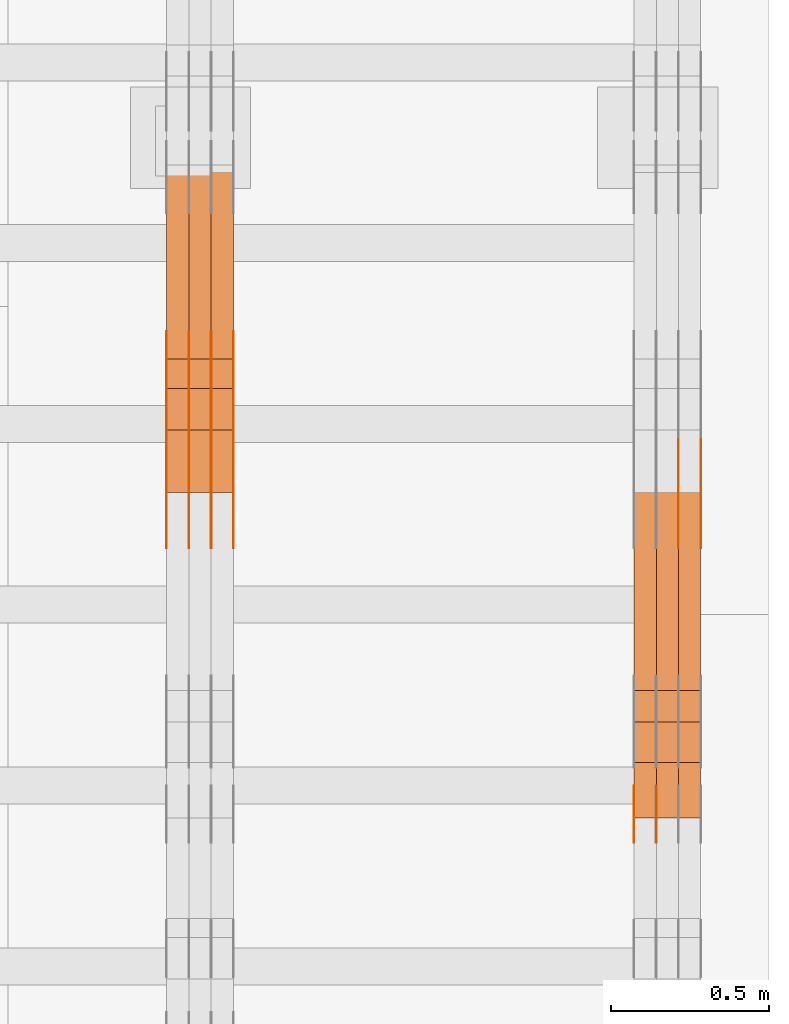
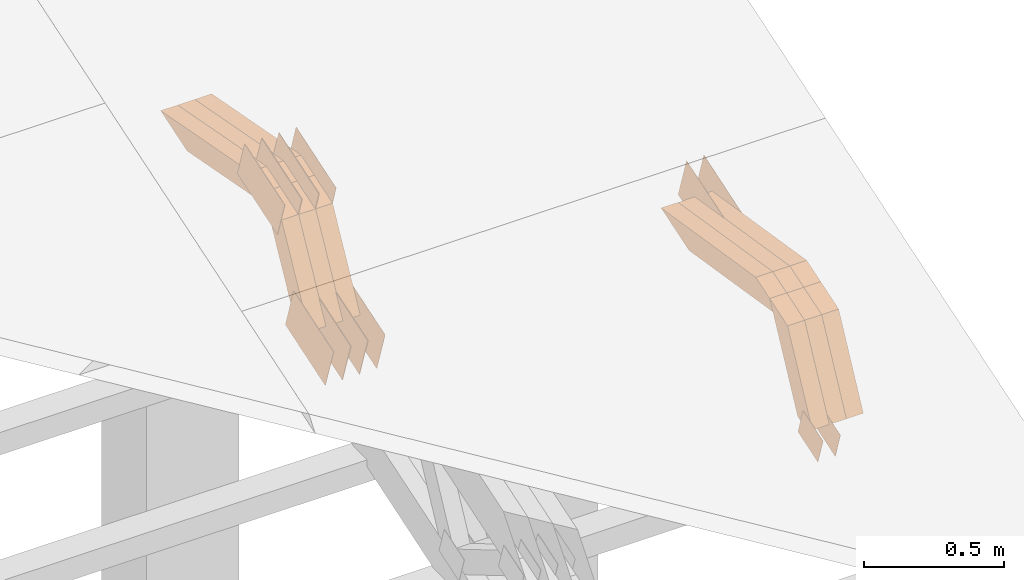
# One storey, part 319 of 385: 28 proxies.
"""IFC2X3 building model written with IfcOpenShell, lengths in millimetres."""

from ifc_helpers import new_model, entity, si_unit, converted_unit, derived_unit, direction, frame, origin, place, context, subcontext, project, spatial, polyline, outline, extrude, source, transform, mapped, material, type_object, type_shapes, element, save


model = new_model("IFC2X3")

# Units and contexts
model_context = context("Model", 3, precision=0.01, world=origin(), true_north=direction((6.12303176911189e-17, 1.0)))
body_context = subcontext(model_context, "Body", "Model", "MODEL_VIEW")
ifc_project = project(units=[si_unit("LENGTHUNIT", "METRE", prefix="MILLI"), si_unit("AREAUNIT", "SQUARE_METRE"), si_unit("VOLUMEUNIT", "CUBIC_METRE"), converted_unit("PLANEANGLEUNIT", "DEGREE", entity("IfcRatioMeasure", 0.0174532925199433), si_unit("PLANEANGLEUNIT", "RADIAN"), dimensions=[0, 0, 0, 0, 0, 0, 0]), si_unit("MASSUNIT", "GRAM", prefix="KILO"), derived_unit("MASSDENSITYUNIT", [(si_unit("MASSUNIT", "GRAM", prefix="KILO"), 1), (si_unit("LENGTHUNIT", "METRE"), -3)]), si_unit("TIMEUNIT", "SECOND"), si_unit("FREQUENCYUNIT", "HERTZ"), si_unit("THERMODYNAMICTEMPERATUREUNIT", "DEGREE_CELSIUS"), derived_unit("THERMALTRANSMITTANCEUNIT", [(si_unit("MASSUNIT", "GRAM", prefix="KILO"), 1), (si_unit("THERMODYNAMICTEMPERATUREUNIT", "KELVIN"), -1), (si_unit("TIMEUNIT", "SECOND"), -3)]), derived_unit("VOLUMETRICFLOWRATEUNIT", [(si_unit("LENGTHUNIT", "METRE"), 3), (si_unit("TIMEUNIT", "SECOND"), -1)]), si_unit("ELECTRICCURRENTUNIT", "AMPERE"), si_unit("ELECTRICVOLTAGEUNIT", "VOLT"), si_unit("POWERUNIT", "WATT"), si_unit("FORCEUNIT", "NEWTON", prefix="KILO"), si_unit("ILLUMINANCEUNIT", "LUX"), si_unit("LUMINOUSFLUXUNIT", "LUMEN"), si_unit("LUMINOUSINTENSITYUNIT", "CANDELA"), derived_unit("USERDEFINED", [(si_unit("MASSUNIT", "GRAM", prefix="KILO"), -1), (si_unit("LENGTHUNIT", "METRE"), -2), (si_unit("TIMEUNIT", "SECOND"), 3), (si_unit("LUMINOUSFLUXUNIT", "LUMEN"), 1)]), derived_unit("LINEARVELOCITYUNIT", [(si_unit("LENGTHUNIT", "METRE"), 1), (si_unit("TIMEUNIT", "SECOND"), -1)]), si_unit("PRESSUREUNIT", "PASCAL"), derived_unit("USERDEFINED", [(si_unit("LENGTHUNIT", "METRE"), -2), (si_unit("MASSUNIT", "GRAM", prefix="KILO"), 1), (si_unit("TIMEUNIT", "SECOND"), -2)])], contexts=[model_context])

# Site, building, storey
site_placement = place(None, origin())
site = spatial("IfcSite", under=ifc_project, at=site_placement, CompositionType="ELEMENT")
building_placement = place(site_placement, origin())
building = spatial("IfcBuilding", under=site, at=building_placement, CompositionType="ELEMENT")
storey_placement = place(building_placement, origin())
storey = spatial("IfcBuildingStorey", under=building, at=storey_placement, Name="Default", CompositionType="ELEMENT", Elevation=0.0)

# Proxies
ifc_material_1 = material(Name="IfcSurfaceStyle #621640")
building_element_proxy_type_1 = type_object("IfcBuildingElementProxyType", PredefinedType="NOTDEFINED", material=ifc_material_1)
shared_shape_1 = source(origin(), body_context, "Body", "SweptSolid", [
    extrude(outline(polyline([(-149.99966632326, -95.9999759039407), (149.999881095801, -95.9999759039407), (150.000557367591, 95.9999759039407), (-150.000772140132, 95.9999759039406), (-149.99966632326, -95.9999759039407)])), frame((150.000557367591, 96.0004291135906, 0.0), z_axis=(0.0, 0.0, 1.0), x_axis=(-1.0, 0.0, 0.0)), (0.0, 0.0, 1.0), 1.29999999999999),
])
type_shapes(building_element_proxy_type_1, [shared_shape_1])
proxy_1_placement = place(building_placement, frame((49861.3, 10934.7734375, 2766.8759765625), z_axis=(-1.0, 0.0, 0.0), x_axis=(0.0, 0.951056516295124, 0.309016994375039)))
element("IfcBuildingElementProxy", 1, at=proxy_1_placement, inside=storey, type_object=building_element_proxy_type_1, material=ifc_material_1, context=body_context, shape_type="MappedRepresentation", body=[
    mapped(shared_shape_1, transform((0.0, 0.0, 0.0), scale=1.0)),
])
ifc_material_2 = material(Name="IfcSurfaceStyle #621583")
building_element_proxy_type_2 = type_object("IfcBuildingElementProxyType", PredefinedType="NOTDEFINED", material=ifc_material_2)
shared_shape_2 = source(origin(), body_context, "Body", "SweptSolid", [
    extrude(outline(polyline([(-149.99966632326, -95.9999759039407), (149.999881095801, -95.9999759039407), (150.000557367591, 95.9999759039407), (-150.000772140132, 95.9999759039406), (-149.99966632326, -95.9999759039407)])), frame((150.000557367591, 96.0004291135906, 0.0), z_axis=(0.0, 0.0, 1.0), x_axis=(-1.0, 0.0, 0.0)), (0.0, 0.0, 1.0), 1.29999999999999),
])
type_shapes(building_element_proxy_type_2, [shared_shape_2])
proxy_2_placement = place(building_placement, frame((49790.0, 10934.7734375, 2766.8759765625), z_axis=(-1.0, 0.0, 0.0), x_axis=(0.0, 0.951056516295124, 0.309016994375039)))
element("IfcBuildingElementProxy", 2, at=proxy_2_placement, inside=storey, type_object=building_element_proxy_type_2, material=ifc_material_2, context=body_context, shape_type="MappedRepresentation", body=[
    mapped(shared_shape_2, transform((0.0, 0.0, 0.0), scale=1.0)),
])
ifc_material_3 = material(Name="IfcSurfaceStyle #621070")
building_element_proxy_type_3 = type_object("IfcBuildingElementProxyType", PredefinedType="NOTDEFINED", material=ifc_material_3)
shared_shape_3 = source(origin(), body_context, "Body", "SweptSolid", [
    extrude(outline(polyline([(-74.9998754286189, -60.0000016373433), (74.9998605591118, -60.0000016373433), (74.9998754286189, 60.0000016373433), (-74.9998605591118, 60.0000016373433), (-74.9998754286189, -60.0000016373433)])), frame((74.9999131819004, 60.0000016373433, 0.0), z_axis=(0.0, 0.0, 1.0), x_axis=(-1.0, 0.0, 0.0)), (0.0, 0.0, 1.0), 1.29999999999999),
])
type_shapes(building_element_proxy_type_3, [shared_shape_3])
proxy_3_placement = place(building_placement, frame((49721.3, 10004.8612689908, 2426.87628052724), z_axis=(-1.0, 0.0, 0.0), x_axis=(0.0, 0.951056516295124, 0.309016994375039)))
element("IfcBuildingElementProxy", 3, at=proxy_3_placement, inside=storey, type_object=building_element_proxy_type_3, material=ifc_material_3, context=body_context, shape_type="MappedRepresentation", body=[
    mapped(shared_shape_3, transform((0.0, 0.0, 0.0), scale=1.0)),
])
ifc_material_4 = material(Name="IfcSurfaceStyle #621013")
building_element_proxy_type_4 = type_object("IfcBuildingElementProxyType", PredefinedType="NOTDEFINED", material=ifc_material_4)
shared_shape_4 = source(origin(), body_context, "Body", "SweptSolid", [
    extrude(outline(polyline([(-74.9998754286189, -60.0000016373433), (74.9998605591118, -60.0000016373433), (74.9998754286189, 60.0000016373433), (-74.9998605591118, 60.0000016373433), (-74.9998754286189, -60.0000016373433)])), frame((74.9999131819004, 60.0000016373433, 0.0), z_axis=(0.0, 0.0, 1.0), x_axis=(-1.0, 0.0, 0.0)), (0.0, 0.0, 1.0), 1.29999999999999),
])
type_shapes(building_element_proxy_type_4, [shared_shape_4])
proxy_4_placement = place(building_placement, frame((49650.0, 10004.8612689908, 2426.87628052724), z_axis=(-1.0, 0.0, 0.0), x_axis=(0.0, 0.951056516295124, 0.309016994375039)))
element("IfcBuildingElementProxy", 4, at=proxy_4_placement, inside=storey, type_object=building_element_proxy_type_4, material=ifc_material_4, context=body_context, shape_type="MappedRepresentation", body=[
    mapped(shared_shape_4, transform((0.0, 0.0, 0.0), scale=1.0)),
])
ifc_material_5 = material(Name="IfcSurfaceStyle #600976")
building_element_proxy_type_5 = type_object("IfcBuildingElementProxyType", Name="T2-W5 600974", PredefinedType="NOTDEFINED", material=ifc_material_5)
shared_shape_5 = source(origin(), body_context, "Body", "SweptSolid", [
    extrude(outline(polyline([(-301.214270081322, -47.5000783565111), (303.980395954293, -47.5000783565111), (288.664123931657, 0.000197935560590153), (195.704076557203, 47.4999793887309), (-487.134326361831, 47.4999793887309), (-301.214270081322, -47.5000783565111)])), frame((303.980395954293, 47.5001815410909, 0.0), z_axis=(0.0, 0.0, 1.0), x_axis=(-1.0, 0.0, 0.0)), (0.0, 0.0, 1.0), 70.0),
])
type_shapes(building_element_proxy_type_5, [shared_shape_5])
proxy_5_placement = place(building_placement, frame((49860.0, 10379.2051671398, 2863.91176079486), z_axis=(-1.0, 0.0, 0.0), x_axis=(0.0, 0.987508363398486, -0.1575665961365)))
element("IfcBuildingElementProxy", 5, at=proxy_5_placement, inside=storey, type_object=building_element_proxy_type_5, material=ifc_material_5, Name="T2-W5", context=body_context, shape_type="MappedRepresentation", body=[
    mapped(shared_shape_5, transform((0.0, 0.0, 0.0), scale=1.0)),
])
ifc_material_6 = material(Name="IfcSurfaceStyle #600910")
building_element_proxy_type_6 = type_object("IfcBuildingElementProxyType", Name="T2-W5 600908", PredefinedType="NOTDEFINED", material=ifc_material_6)
shared_shape_6 = source(origin(), body_context, "Body", "SweptSolid", [
    extrude(outline(polyline([(-301.214270081322, -47.5000783565111), (303.980395954293, -47.5000783565111), (288.664123931657, 0.000197935560590153), (195.704076557203, 47.4999793887309), (-487.134326361831, 47.4999793887309), (-301.214270081322, -47.5000783565111)])), frame((303.980395954293, 47.5001815410909, 0.0), z_axis=(0.0, 0.0, 1.0), x_axis=(-1.0, 0.0, 0.0)), (0.0, 0.0, 1.0), 70.0),
])
type_shapes(building_element_proxy_type_6, [shared_shape_6])
proxy_6_placement = place(building_placement, frame((49790.0, 10379.2051671398, 2863.91176079486), z_axis=(-1.0, 0.0, 0.0), x_axis=(0.0, 0.987508363398486, -0.1575665961365)))
element("IfcBuildingElementProxy", 6, at=proxy_6_placement, inside=storey, type_object=building_element_proxy_type_6, material=ifc_material_6, Name="T2-W5", context=body_context, shape_type="MappedRepresentation", body=[
    mapped(shared_shape_6, transform((0.0, 0.0, 0.0), scale=1.0)),
])
ifc_material_7 = material(Name="IfcSurfaceStyle #600844")
building_element_proxy_type_7 = type_object("IfcBuildingElementProxyType", Name="T2-W5 600842", PredefinedType="NOTDEFINED", material=ifc_material_7)
shared_shape_7 = source(origin(), body_context, "Body", "SweptSolid", [
    extrude(outline(polyline([(-301.214270081322, -47.5000783565111), (303.980395954293, -47.5000783565111), (288.664123931657, 0.000197935560590153), (195.704076557203, 47.4999793887309), (-487.134326361831, 47.4999793887309), (-301.214270081322, -47.5000783565111)])), frame((303.980395954293, 47.5001815410909, 0.0), z_axis=(0.0, 0.0, 1.0), x_axis=(-1.0, 0.0, 0.0)), (0.0, 0.0, 1.0), 70.0),
])
type_shapes(building_element_proxy_type_7, [shared_shape_7])
proxy_7_placement = place(building_placement, frame((49720.0, 10379.2051671398, 2863.91176079486), z_axis=(-1.0, 0.0, 0.0), x_axis=(0.0, 0.987508363398486, -0.1575665961365)))
element("IfcBuildingElementProxy", 7, at=proxy_7_placement, inside=storey, type_object=building_element_proxy_type_7, material=ifc_material_7, Name="T2-W5", context=body_context, shape_type="MappedRepresentation", body=[
    mapped(shared_shape_7, transform((0.0, 0.0, 0.0), scale=1.0)),
])
ifc_material_8 = material(Name="IfcSurfaceStyle #600580")
building_element_proxy_type_8 = type_object("IfcBuildingElementProxyType", Name="T2-W37 600578", PredefinedType="NOTDEFINED", material=ifc_material_8)
shared_shape_8 = source(origin(), body_context, "Body", "SweptSolid", [
    extrude(outline(polyline([(111.787482004227, -179.289397746839), (245.990585035629, -179.289397746839), (-64.0177573255029, 131.410401861866), (-131.116409377007, 131.410958895698), (-162.643900337347, 95.757434736113), (111.787482004227, -179.289397746839)])), frame((185.635323570343, 47.5011799885346, 0.0), z_axis=(0.0, 0.0, 1.0), x_axis=(0.706316677358935, 0.707896003156279, 0.0)), (0.0, 0.0, 1.0), 70.0),
])
type_shapes(building_element_proxy_type_8, [shared_shape_8])
proxy_8_placement = place(building_placement, frame((49860.0, 10081.8581176196, 2424.08390440728), z_axis=(-1.0, 0.0, 0.0), x_axis=(0.0, 0.452995827831714, 0.891512635898707)))
element("IfcBuildingElementProxy", 8, at=proxy_8_placement, inside=storey, type_object=building_element_proxy_type_8, material=ifc_material_8, Name="T2-W37", context=body_context, shape_type="MappedRepresentation", body=[
    mapped(shared_shape_8, transform((0.0, 0.0, 0.0), scale=1.0)),
])
ifc_material_9 = material(Name="IfcSurfaceStyle #600514")
building_element_proxy_type_9 = type_object("IfcBuildingElementProxyType", Name="T2-W37 600512", PredefinedType="NOTDEFINED", material=ifc_material_9)
shared_shape_9 = source(origin(), body_context, "Body", "SweptSolid", [
    extrude(outline(polyline([(111.787482004227, -179.289397746839), (245.990585035629, -179.289397746839), (-64.0177573255029, 131.410401861866), (-131.116409377007, 131.410958895698), (-162.643900337347, 95.757434736113), (111.787482004227, -179.289397746839)])), frame((185.635323570343, 47.5011799885346, 0.0), z_axis=(0.0, 0.0, 1.0), x_axis=(0.706316677358935, 0.707896003156279, 0.0)), (0.0, 0.0, 1.0), 70.0),
])
type_shapes(building_element_proxy_type_9, [shared_shape_9])
proxy_9_placement = place(building_placement, frame((49790.0, 10081.8581176196, 2424.08390440728), z_axis=(-1.0, 0.0, 0.0), x_axis=(0.0, 0.452995827831714, 0.891512635898707)))
element("IfcBuildingElementProxy", 9, at=proxy_9_placement, inside=storey, type_object=building_element_proxy_type_9, material=ifc_material_9, Name="T2-W37", context=body_context, shape_type="MappedRepresentation", body=[
    mapped(shared_shape_9, transform((0.0, 0.0, 0.0), scale=1.0)),
])
ifc_material_10 = material(Name="IfcSurfaceStyle #600448")
building_element_proxy_type_10 = type_object("IfcBuildingElementProxyType", Name="T2-W37 600446", PredefinedType="NOTDEFINED", material=ifc_material_10)
shared_shape_10 = source(origin(), body_context, "Body", "SweptSolid", [
    extrude(outline(polyline([(111.787482004227, -179.289397746839), (245.990585035629, -179.289397746839), (-64.0177573255029, 131.410401861866), (-131.116409377007, 131.410958895698), (-162.643900337347, 95.757434736113), (111.787482004227, -179.289397746839)])), frame((185.635323570343, 47.5011799885346, 0.0), z_axis=(0.0, 0.0, 1.0), x_axis=(0.706316677358935, 0.707896003156279, 0.0)), (0.0, 0.0, 1.0), 70.0),
])
type_shapes(building_element_proxy_type_10, [shared_shape_10])
proxy_10_placement = place(building_placement, frame((49720.0, 10081.8581176196, 2424.08390440728), z_axis=(-1.0, 0.0, 0.0), x_axis=(0.0, 0.452995827831714, 0.891512635898707)))
element("IfcBuildingElementProxy", 10, at=proxy_10_placement, inside=storey, type_object=building_element_proxy_type_10, material=ifc_material_10, Name="T2-W37", context=body_context, shape_type="MappedRepresentation", body=[
    mapped(shared_shape_10, transform((0.0, 0.0, 0.0), scale=1.0)),
])
ifc_material_11 = material(Name="IfcSurfaceStyle #587208")
building_element_proxy_type_11 = type_object("IfcBuildingElementProxyType", PredefinedType="NOTDEFINED", material=ifc_material_11)
shared_shape_11 = source(origin(), body_context, "Body", "SweptSolid", [
    extrude(outline(polyline([(-149.99966632326, -95.9999759039407), (149.999881095801, -95.9999759039407), (150.000557367591, 95.9999759039407), (-150.000772140132, 95.9999759039406), (-149.99966632326, -95.9999759039407)])), frame((150.000557367591, 96.0004291135906, 0.0), z_axis=(0.0, 0.0, 1.0), x_axis=(-1.0, 0.0, 0.0)), (0.0, 0.0, 1.0), 1.29999999999999),
])
type_shapes(building_element_proxy_type_11, [shared_shape_11])
proxy_11_placement = place(building_placement, frame((48386.3, 10934.7734375, 2766.8759765625), z_axis=(-1.0, 0.0, 0.0), x_axis=(0.0, 0.951056516295124, 0.309016994375039)))
element("IfcBuildingElementProxy", 11, at=proxy_11_placement, inside=storey, type_object=building_element_proxy_type_11, material=ifc_material_11, context=body_context, shape_type="MappedRepresentation", body=[
    mapped(shared_shape_11, transform((0.0, 0.0, 0.0), scale=1.0)),
])
ifc_material_12 = material(Name="IfcSurfaceStyle #587151")
building_element_proxy_type_12 = type_object("IfcBuildingElementProxyType", PredefinedType="NOTDEFINED", material=ifc_material_12)
shared_shape_12 = source(origin(), body_context, "Body", "SweptSolid", [
    extrude(outline(polyline([(-149.99966632326, -95.9999759039407), (149.999881095801, -95.9999759039407), (150.000557367591, 95.9999759039407), (-150.000772140132, 95.9999759039406), (-149.99966632326, -95.9999759039407)])), frame((150.000557367591, 96.0004291135906, 0.0), z_axis=(0.0, 0.0, 1.0), x_axis=(-1.0, 0.0, 0.0)), (0.0, 0.0, 1.0), 1.29999999999999),
])
type_shapes(building_element_proxy_type_12, [shared_shape_12])
proxy_12_placement = place(building_placement, frame((48315.0, 10934.7734375, 2766.8759765625), z_axis=(-1.0, 0.0, 0.0), x_axis=(0.0, 0.951056516295124, 0.309016994375039)))
element("IfcBuildingElementProxy", 12, at=proxy_12_placement, inside=storey, type_object=building_element_proxy_type_12, material=ifc_material_12, context=body_context, shape_type="MappedRepresentation", body=[
    mapped(shared_shape_12, transform((0.0, 0.0, 0.0), scale=1.0)),
])
ifc_material_13 = material(Name="IfcSurfaceStyle #587094")
building_element_proxy_type_13 = type_object("IfcBuildingElementProxyType", PredefinedType="NOTDEFINED", material=ifc_material_13)
shared_shape_13 = source(origin(), body_context, "Body", "SweptSolid", [
    extrude(outline(polyline([(-149.99966632326, -95.9999759039407), (149.999881095801, -95.9999759039407), (150.000557367591, 95.9999759039407), (-150.000772140132, 95.9999759039406), (-149.99966632326, -95.9999759039407)])), frame((150.000557367591, 96.0004291135906, 0.0), z_axis=(0.0, 0.0, 1.0), x_axis=(-1.0, 0.0, 0.0)), (0.0, 0.0, 1.0), 1.29999999999999),
])
type_shapes(building_element_proxy_type_13, [shared_shape_13])
proxy_13_placement = place(building_placement, frame((48316.3, 10934.7734375, 2766.8759765625), z_axis=(-1.0, 0.0, 0.0), x_axis=(0.0, 0.951056516295124, 0.309016994375039)))
element("IfcBuildingElementProxy", 13, at=proxy_13_placement, inside=storey, type_object=building_element_proxy_type_13, material=ifc_material_13, context=body_context, shape_type="MappedRepresentation", body=[
    mapped(shared_shape_13, transform((0.0, 0.0, 0.0), scale=1.0)),
])
ifc_material_14 = material(Name="IfcSurfaceStyle #587037")
building_element_proxy_type_14 = type_object("IfcBuildingElementProxyType", PredefinedType="NOTDEFINED", material=ifc_material_14)
shared_shape_14 = source(origin(), body_context, "Body", "SweptSolid", [
    extrude(outline(polyline([(-149.99966632326, -95.9999759039407), (149.999881095801, -95.9999759039407), (150.000557367591, 95.9999759039407), (-150.000772140132, 95.9999759039406), (-149.99966632326, -95.9999759039407)])), frame((150.000557367591, 96.0004291135906, 0.0), z_axis=(0.0, 0.0, 1.0), x_axis=(-1.0, 0.0, 0.0)), (0.0, 0.0, 1.0), 1.29999999999998),
])
type_shapes(building_element_proxy_type_14, [shared_shape_14])
proxy_14_placement = place(building_placement, frame((48245.0, 10934.7734375, 2766.8759765625), z_axis=(-1.0, 0.0, 0.0), x_axis=(0.0, 0.951056516295124, 0.309016994375039)))
element("IfcBuildingElementProxy", 14, at=proxy_14_placement, inside=storey, type_object=building_element_proxy_type_14, material=ifc_material_14, context=body_context, shape_type="MappedRepresentation", body=[
    mapped(shared_shape_14, transform((0.0, 0.0, 0.0), scale=1.0)),
])
ifc_material_15 = material(Name="IfcSurfaceStyle #586980")
building_element_proxy_type_15 = type_object("IfcBuildingElementProxyType", PredefinedType="NOTDEFINED", material=ifc_material_15)
shared_shape_15 = source(origin(), body_context, "Body", "SweptSolid", [
    extrude(outline(polyline([(-149.99966632326, -95.9999759039407), (149.999881095801, -95.9999759039407), (150.000557367591, 95.9999759039407), (-150.000772140132, 95.9999759039406), (-149.99966632326, -95.9999759039407)])), frame((150.000557367591, 96.0004291135906, 0.0), z_axis=(0.0, 0.0, 1.0), x_axis=(-1.0, 0.0, 0.0)), (0.0, 0.0, 1.0), 1.29999999999998),
])
type_shapes(building_element_proxy_type_15, [shared_shape_15])
proxy_15_placement = place(building_placement, frame((48246.3, 10934.7734375, 2766.8759765625), z_axis=(-1.0, 0.0, 0.0), x_axis=(0.0, 0.951056516295124, 0.309016994375039)))
element("IfcBuildingElementProxy", 15, at=proxy_15_placement, inside=storey, type_object=building_element_proxy_type_15, material=ifc_material_15, context=body_context, shape_type="MappedRepresentation", body=[
    mapped(shared_shape_15, transform((0.0, 0.0, 0.0), scale=1.0)),
])
ifc_material_16 = material(Name="IfcSurfaceStyle #586923")
building_element_proxy_type_16 = type_object("IfcBuildingElementProxyType", PredefinedType="NOTDEFINED", material=ifc_material_16)
shared_shape_16 = source(origin(), body_context, "Body", "SweptSolid", [
    extrude(outline(polyline([(-149.99966632326, -95.9999759039407), (149.999881095801, -95.9999759039407), (150.000557367591, 95.9999759039407), (-150.000772140132, 95.9999759039406), (-149.99966632326, -95.9999759039407)])), frame((150.000557367591, 96.0004291135906, 0.0), z_axis=(0.0, 0.0, 1.0), x_axis=(-1.0, 0.0, 0.0)), (0.0, 0.0, 1.0), 1.29999999999998),
])
type_shapes(building_element_proxy_type_16, [shared_shape_16])
proxy_16_placement = place(building_placement, frame((48175.0, 10934.7734375, 2766.8759765625), z_axis=(-1.0, 0.0, 0.0), x_axis=(0.0, 0.951056516295124, 0.309016994375039)))
element("IfcBuildingElementProxy", 16, at=proxy_16_placement, inside=storey, type_object=building_element_proxy_type_16, material=ifc_material_16, context=body_context, shape_type="MappedRepresentation", body=[
    mapped(shared_shape_16, transform((0.0, 0.0, 0.0), scale=1.0)),
])
ifc_material_17 = material(Name="IfcSurfaceStyle #577632")
building_element_proxy_type_17 = type_object("IfcBuildingElementProxyType", PredefinedType="NOTDEFINED", material=ifc_material_17)
shared_shape_17 = source(origin(), body_context, "Body", "SweptSolid", [
    extrude(outline(polyline([(-150.000273478628, -84.0002987844282), (149.999198496832, -84.0002987844282), (150.000273478627, 84.0002987844282), (-149.999198496831, 84.0002987844282), (-150.000273478628, -84.0002987844282)])), frame((150.000273478627, 84.0002987844282, 0.0), z_axis=(0.0, 0.0, 1.0), x_axis=(-1.0, 0.0, 0.0)), (0.0, 0.0, 1.0), 1.29999999999999),
])
type_shapes(building_element_proxy_type_17, [shared_shape_17])
proxy_17_placement = place(building_placement, frame((48386.3, 11283.0116722926, 3194.09682266857), z_axis=(-1.0, 0.0, 0.0), x_axis=(0.0, 0.951056516295154, 0.309016994374948)))
element("IfcBuildingElementProxy", 17, at=proxy_17_placement, inside=storey, type_object=building_element_proxy_type_17, material=ifc_material_17, context=body_context, shape_type="MappedRepresentation", body=[
    mapped(shared_shape_17, transform((0.0, 0.0, 0.0), scale=1.0)),
])
ifc_material_18 = material(Name="IfcSurfaceStyle #577575")
building_element_proxy_type_18 = type_object("IfcBuildingElementProxyType", PredefinedType="NOTDEFINED", material=ifc_material_18)
shared_shape_18 = source(origin(), body_context, "Body", "SweptSolid", [
    extrude(outline(polyline([(-150.000273478628, -84.0002987844282), (149.999198496832, -84.0002987844282), (150.000273478627, 84.0002987844282), (-149.999198496831, 84.0002987844282), (-150.000273478628, -84.0002987844282)])), frame((150.000273478627, 84.0002987844282, 0.0), z_axis=(0.0, 0.0, 1.0), x_axis=(-1.0, 0.0, 0.0)), (0.0, 0.0, 1.0), 1.29999999999999),
])
type_shapes(building_element_proxy_type_18, [shared_shape_18])
proxy_18_placement = place(building_placement, frame((48315.0, 11283.0116722926, 3194.09682266857), z_axis=(-1.0, 0.0, 0.0), x_axis=(0.0, 0.951056516295154, 0.309016994374948)))
element("IfcBuildingElementProxy", 18, at=proxy_18_placement, inside=storey, type_object=building_element_proxy_type_18, material=ifc_material_18, context=body_context, shape_type="MappedRepresentation", body=[
    mapped(shared_shape_18, transform((0.0, 0.0, 0.0), scale=1.0)),
])
ifc_material_19 = material(Name="IfcSurfaceStyle #577518")
building_element_proxy_type_19 = type_object("IfcBuildingElementProxyType", PredefinedType="NOTDEFINED", material=ifc_material_19)
shared_shape_19 = source(origin(), body_context, "Body", "SweptSolid", [
    extrude(outline(polyline([(-150.000273478628, -84.0002987844282), (149.999198496832, -84.0002987844282), (150.000273478627, 84.0002987844282), (-149.999198496831, 84.0002987844282), (-150.000273478628, -84.0002987844282)])), frame((150.000273478627, 84.0002987844282, 0.0), z_axis=(0.0, 0.0, 1.0), x_axis=(-1.0, 0.0, 0.0)), (0.0, 0.0, 1.0), 1.29999999999999),
])
type_shapes(building_element_proxy_type_19, [shared_shape_19])
proxy_19_placement = place(building_placement, frame((48316.3, 11283.0116722926, 3194.09682266857), z_axis=(-1.0, 0.0, 0.0), x_axis=(0.0, 0.951056516295154, 0.309016994374948)))
element("IfcBuildingElementProxy", 19, at=proxy_19_placement, inside=storey, type_object=building_element_proxy_type_19, material=ifc_material_19, context=body_context, shape_type="MappedRepresentation", body=[
    mapped(shared_shape_19, transform((0.0, 0.0, 0.0), scale=1.0)),
])
ifc_material_20 = material(Name="IfcSurfaceStyle #577461")
building_element_proxy_type_20 = type_object("IfcBuildingElementProxyType", PredefinedType="NOTDEFINED", material=ifc_material_20)
shared_shape_20 = source(origin(), body_context, "Body", "SweptSolid", [
    extrude(outline(polyline([(-150.000273478628, -84.0002987844282), (149.999198496832, -84.0002987844282), (150.000273478627, 84.0002987844282), (-149.999198496831, 84.0002987844282), (-150.000273478628, -84.0002987844282)])), frame((150.000273478627, 84.0002987844282, 0.0), z_axis=(0.0, 0.0, 1.0), x_axis=(-1.0, 0.0, 0.0)), (0.0, 0.0, 1.0), 1.29999999999998),
])
type_shapes(building_element_proxy_type_20, [shared_shape_20])
proxy_20_placement = place(building_placement, frame((48245.0, 11283.0116722926, 3194.09682266857), z_axis=(-1.0, 0.0, 0.0), x_axis=(0.0, 0.951056516295154, 0.309016994374948)))
element("IfcBuildingElementProxy", 20, at=proxy_20_placement, inside=storey, type_object=building_element_proxy_type_20, material=ifc_material_20, context=body_context, shape_type="MappedRepresentation", body=[
    mapped(shared_shape_20, transform((0.0, 0.0, 0.0), scale=1.0)),
])
ifc_material_21 = material(Name="IfcSurfaceStyle #577404")
building_element_proxy_type_21 = type_object("IfcBuildingElementProxyType", PredefinedType="NOTDEFINED", material=ifc_material_21)
shared_shape_21 = source(origin(), body_context, "Body", "SweptSolid", [
    extrude(outline(polyline([(-150.000273478628, -84.0002987844282), (149.999198496832, -84.0002987844282), (150.000273478627, 84.0002987844282), (-149.999198496831, 84.0002987844282), (-150.000273478628, -84.0002987844282)])), frame((150.000273478627, 84.0002987844282, 0.0), z_axis=(0.0, 0.0, 1.0), x_axis=(-1.0, 0.0, 0.0)), (0.0, 0.0, 1.0), 1.29999999999998),
])
type_shapes(building_element_proxy_type_21, [shared_shape_21])
proxy_21_placement = place(building_placement, frame((48246.3, 11283.0116722926, 3194.09682266857), z_axis=(-1.0, 0.0, 0.0), x_axis=(0.0, 0.951056516295154, 0.309016994374948)))
element("IfcBuildingElementProxy", 21, at=proxy_21_placement, inside=storey, type_object=building_element_proxy_type_21, material=ifc_material_21, context=body_context, shape_type="MappedRepresentation", body=[
    mapped(shared_shape_21, transform((0.0, 0.0, 0.0), scale=1.0)),
])
ifc_material_22 = material(Name="IfcSurfaceStyle #577347")
building_element_proxy_type_22 = type_object("IfcBuildingElementProxyType", PredefinedType="NOTDEFINED", material=ifc_material_22)
shared_shape_22 = source(origin(), body_context, "Body", "SweptSolid", [
    extrude(outline(polyline([(-150.000273478628, -84.0002987844282), (149.999198496832, -84.0002987844282), (150.000273478627, 84.0002987844282), (-149.999198496831, 84.0002987844282), (-150.000273478628, -84.0002987844282)])), frame((150.000273478627, 84.0002987844282, 0.0), z_axis=(0.0, 0.0, 1.0), x_axis=(-1.0, 0.0, 0.0)), (0.0, 0.0, 1.0), 1.29999999999998),
])
type_shapes(building_element_proxy_type_22, [shared_shape_22])
proxy_22_placement = place(building_placement, frame((48175.0, 11283.0116722926, 3194.09682266857), z_axis=(-1.0, 0.0, 0.0), x_axis=(0.0, 0.951056516295154, 0.309016994374948)))
element("IfcBuildingElementProxy", 22, at=proxy_22_placement, inside=storey, type_object=building_element_proxy_type_22, material=ifc_material_22, context=body_context, shape_type="MappedRepresentation", body=[
    mapped(shared_shape_22, transform((0.0, 0.0, 0.0), scale=1.0)),
])
ifc_material_23 = material(Name="IfcSurfaceStyle #567336")
building_element_proxy_type_23 = type_object("IfcBuildingElementProxyType", Name="T1-W9 567334", PredefinedType="NOTDEFINED", material=ifc_material_23)
shared_shape_23 = source(origin(), body_context, "Body", "SweptSolid", [
    extrude(outline(polyline([(-287.457507623288, -47.5000268597988), (288.590479960635, -47.5000268597988), (273.55062971372, -2.33146189358546e-05), (186.625054999886, 47.5000385171083), (-461.308657050953, 47.5000385171083), (-287.457507623288, -47.5000268597988)])), frame((288.590945855618, 47.5000968036551, 0.0), z_axis=(0.0, 0.0, 1.0), x_axis=(-1.0, 0.0, 0.0)), (0.0, 0.0, 1.0), 70.0),
])
type_shapes(building_element_proxy_type_23, [shared_shape_23])
proxy_23_placement = place(building_placement, frame((48385.0, 11432.1200855376, 3205.63308612017), z_axis=(-1.0, 0.0, 0.0), x_axis=(0.0, 0.982760503514031, -0.184883186722992)))
element("IfcBuildingElementProxy", 23, at=proxy_23_placement, inside=storey, type_object=building_element_proxy_type_23, material=ifc_material_23, Name="T1-W9", context=body_context, shape_type="MappedRepresentation", body=[
    mapped(shared_shape_23, transform((0.0, 0.0, 0.0), scale=1.0)),
])
ifc_material_24 = material(Name="IfcSurfaceStyle #567270")
building_element_proxy_type_24 = type_object("IfcBuildingElementProxyType", Name="T1-W9 567268", PredefinedType="NOTDEFINED", material=ifc_material_24)
shared_shape_24 = source(origin(), body_context, "Body", "SweptSolid", [
    extrude(outline(polyline([(-287.457507623288, -47.5000268597988), (288.590479960635, -47.5000268597988), (273.55062971372, -2.33146189358546e-05), (186.625054999886, 47.5000385171083), (-461.308657050953, 47.5000385171083), (-287.457507623288, -47.5000268597988)])), frame((288.590945855618, 47.5000968036551, 0.0), z_axis=(0.0, 0.0, 1.0), x_axis=(-1.0, 0.0, 0.0)), (0.0, 0.0, 1.0), 70.0),
])
type_shapes(building_element_proxy_type_24, [shared_shape_24])
proxy_24_placement = place(building_placement, frame((48315.0, 11432.1200855376, 3205.63308612017), z_axis=(-1.0, 0.0, 0.0), x_axis=(0.0, 0.982760503514031, -0.184883186722992)))
element("IfcBuildingElementProxy", 24, at=proxy_24_placement, inside=storey, type_object=building_element_proxy_type_24, material=ifc_material_24, Name="T1-W9", context=body_context, shape_type="MappedRepresentation", body=[
    mapped(shared_shape_24, transform((0.0, 0.0, 0.0), scale=1.0)),
])
ifc_material_25 = material(Name="IfcSurfaceStyle #567204")
building_element_proxy_type_25 = type_object("IfcBuildingElementProxyType", Name="T1-W9 567202", PredefinedType="NOTDEFINED", material=ifc_material_25)
shared_shape_25 = source(origin(), body_context, "Body", "SweptSolid", [
    extrude(outline(polyline([(-287.457507623288, -47.5000268597988), (288.590479960635, -47.5000268597988), (273.55062971372, -2.33146189358546e-05), (186.625054999886, 47.5000385171083), (-461.308657050953, 47.5000385171083), (-287.457507623288, -47.5000268597988)])), frame((288.590945855618, 47.5000968036551, 0.0), z_axis=(0.0, 0.0, 1.0), x_axis=(-1.0, 0.0, 0.0)), (0.0, 0.0, 1.0), 70.0),
])
type_shapes(building_element_proxy_type_25, [shared_shape_25])
proxy_25_placement = place(building_placement, frame((48245.0, 11432.1200855376, 3205.63308612017), z_axis=(-1.0, 0.0, 0.0), x_axis=(0.0, 0.982760503514031, -0.184883186722992)))
element("IfcBuildingElementProxy", 25, at=proxy_25_placement, inside=storey, type_object=building_element_proxy_type_25, material=ifc_material_25, Name="T1-W9", context=body_context, shape_type="MappedRepresentation", body=[
    mapped(shared_shape_25, transform((0.0, 0.0, 0.0), scale=1.0)),
])
ifc_material_26 = material(Name="IfcSurfaceStyle #566940")
building_element_proxy_type_26 = type_object("IfcBuildingElementProxyType", Name="T1-W32 566938", PredefinedType="NOTDEFINED", material=ifc_material_26)
shared_shape_26 = source(origin(), body_context, "Body", "SweptSolid", [
    extrude(outline(polyline([(-312.414547135921, -47.5000544873059), (136.677011757652, -47.5000544873059), (186.250996577889, 0.000369497452627243), (202.753116295831, 47.4998697385796), (-213.26657749545, 47.4998697385796), (-312.414547135921, -47.5000544873059)])), frame((202.753376481939, 47.5001296985553, 0.0), z_axis=(0.0, 0.0, 1.0), x_axis=(-1.0, 0.0, 0.0)), (0.0, 0.0, 1.0), 70.0),
])
type_shapes(building_element_proxy_type_26, [shared_shape_26])
proxy_26_placement = place(building_placement, frame((48385.0, 11110.7808979007, 2747.18129017315), z_axis=(-1.0, 0.0, 0.0), x_axis=(0.0, 0.472919689385906, 0.881105537033526)))
element("IfcBuildingElementProxy", 26, at=proxy_26_placement, inside=storey, type_object=building_element_proxy_type_26, material=ifc_material_26, Name="T1-W32", context=body_context, shape_type="MappedRepresentation", body=[
    mapped(shared_shape_26, transform((0.0, 0.0, 0.0), scale=1.0)),
])
ifc_material_27 = material(Name="IfcSurfaceStyle #566874")
building_element_proxy_type_27 = type_object("IfcBuildingElementProxyType", Name="T1-W32 566872", PredefinedType="NOTDEFINED", material=ifc_material_27)
shared_shape_27 = source(origin(), body_context, "Body", "SweptSolid", [
    extrude(outline(polyline([(-312.414547135921, -47.5000544873059), (136.677011757652, -47.5000544873059), (186.250996577889, 0.000369497452627243), (202.753116295831, 47.4998697385796), (-213.26657749545, 47.4998697385796), (-312.414547135921, -47.5000544873059)])), frame((202.753376481939, 47.5001296985553, 0.0), z_axis=(0.0, 0.0, 1.0), x_axis=(-1.0, 0.0, 0.0)), (0.0, 0.0, 1.0), 70.0),
])
type_shapes(building_element_proxy_type_27, [shared_shape_27])
proxy_27_placement = place(building_placement, frame((48315.0, 11110.7808979007, 2747.18129017315), z_axis=(-1.0, 0.0, 0.0), x_axis=(0.0, 0.472919689385906, 0.881105537033526)))
element("IfcBuildingElementProxy", 27, at=proxy_27_placement, inside=storey, type_object=building_element_proxy_type_27, material=ifc_material_27, Name="T1-W32", context=body_context, shape_type="MappedRepresentation", body=[
    mapped(shared_shape_27, transform((0.0, 0.0, 0.0), scale=1.0)),
])
ifc_material_28 = material(Name="IfcSurfaceStyle #566808")
building_element_proxy_type_28 = type_object("IfcBuildingElementProxyType", Name="T1-W32 566806", PredefinedType="NOTDEFINED", material=ifc_material_28)
shared_shape_28 = source(origin(), body_context, "Body", "SweptSolid", [
    extrude(outline(polyline([(-312.414547135921, -47.5000544873059), (136.677011757652, -47.5000544873059), (186.250996577889, 0.000369497452627243), (202.753116295831, 47.4998697385796), (-213.26657749545, 47.4998697385796), (-312.414547135921, -47.5000544873059)])), frame((202.753376481939, 47.5001296985553, 0.0), z_axis=(0.0, 0.0, 1.0), x_axis=(-1.0, 0.0, 0.0)), (0.0, 0.0, 1.0), 70.0),
])
type_shapes(building_element_proxy_type_28, [shared_shape_28])
proxy_28_placement = place(building_placement, frame((48245.0, 11110.7808979007, 2747.18129017315), z_axis=(-1.0, 0.0, 0.0), x_axis=(0.0, 0.472919689385906, 0.881105537033526)))
element("IfcBuildingElementProxy", 28, at=proxy_28_placement, inside=storey, type_object=building_element_proxy_type_28, material=ifc_material_28, Name="T1-W32", context=body_context, shape_type="MappedRepresentation", body=[
    mapped(shared_shape_28, transform((0.0, 0.0, 0.0), scale=1.0)),
])

save(model, "model.ifc")
